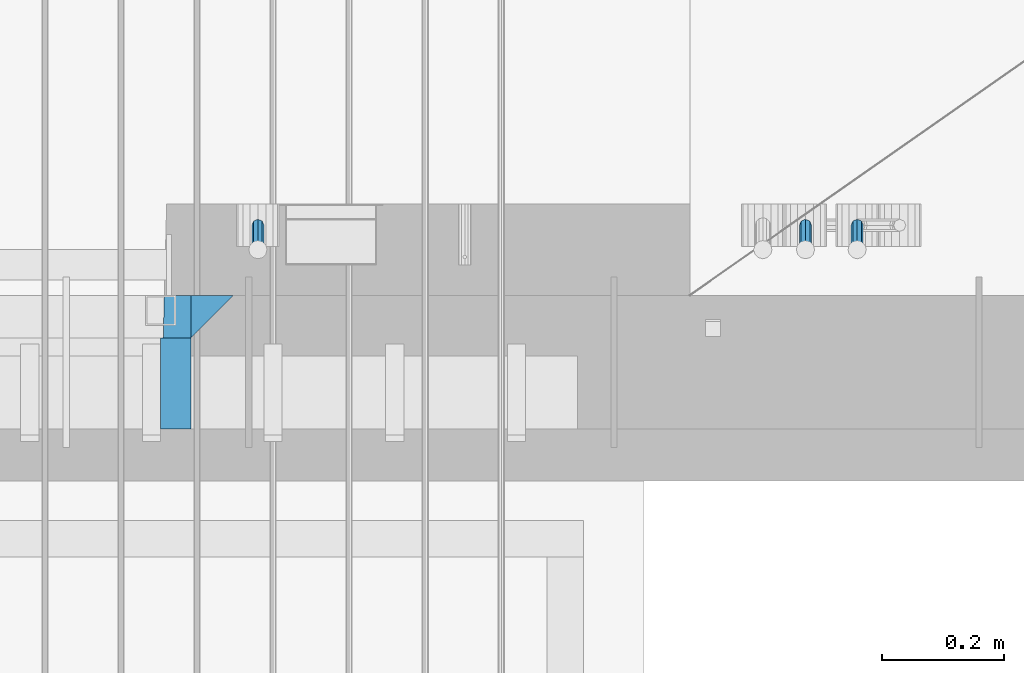
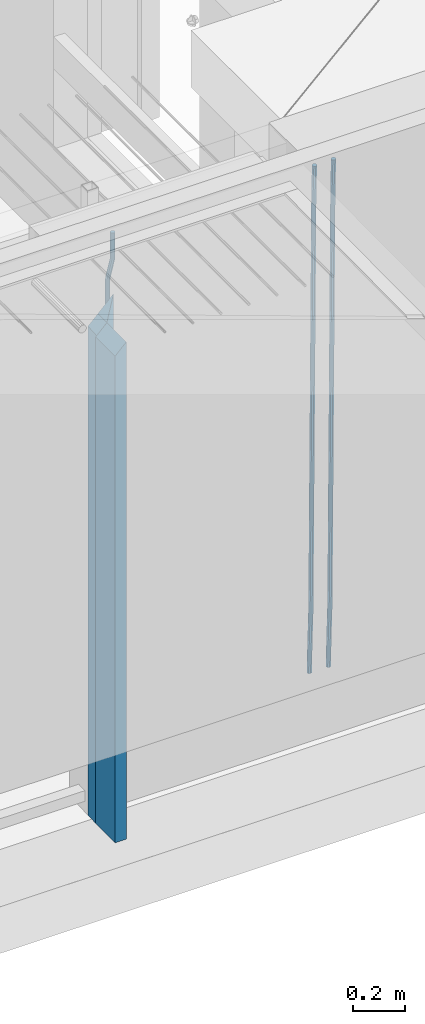
# One storey, part 112 of 325: 6 beams, 1 element without a shape of its own.
"""IFC2X3 building model written with IfcOpenShell, lengths in millimetres."""

from ifc_helpers import new_model, si_unit, frame, origin_with_axes, place, context, subcontext, project, spatial, faceted_brep, material, type_object, element, aggregate, save


model = new_model("IFC2X3")

# Units and contexts
model_context = context("Model", 3, precision=1e-05, world=origin_with_axes())
body_context = subcontext(model_context, "Body", "Model", "MODEL_VIEW")
ifc_project = project(units=[si_unit("LENGTHUNIT", "METRE", prefix="MILLI"), si_unit("AREAUNIT", "SQUARE_METRE"), si_unit("VOLUMEUNIT", "CUBIC_METRE"), si_unit("MASSUNIT", "GRAM", prefix="KILO"), si_unit("TIMEUNIT", "SECOND"), si_unit("PLANEANGLEUNIT", "RADIAN"), si_unit("SOLIDANGLEUNIT", "STERADIAN"), si_unit("THERMODYNAMICTEMPERATUREUNIT", "DEGREE_CELSIUS"), si_unit("LUMINOUSINTENSITYUNIT", "LUMEN")], contexts=[model_context])

# Site, building, storey
site_placement = place(None, origin_with_axes())
site = spatial("IfcSite", under=ifc_project, at=site_placement, CompositionType="ELEMENT")
building_placement = place(site_placement, origin_with_axes())
building = spatial("IfcBuilding", under=site, at=building_placement, CompositionType="ELEMENT")
storey_placement = place(building_placement, origin_with_axes())
storey = spatial("IfcBuildingStorey", under=building, at=storey_placement, Name="1", CompositionType="ELEMENT", Elevation=0.0)

# Assembly, beams
assembly_placement = place(storey_placement, origin_with_axes())
assembly = element("IfcElementAssembly", 1, at=assembly_placement, inside=storey, AssemblyPlace="NOTDEFINED", PredefinedType="REINFORCEMENT_UNIT")
ifc_material_1 = material(Name="CONCRETE/C35/45")
beam_type_1 = type_object("IfcBeamType", PredefinedType="NOTDEFINED")
beam_1_placement = place(assembly_placement, frame((33199.9988923323, 7815.0, 84175.0), z_axis=(-1.0, 3.00000001838171e-08, 0.0), x_axis=(0.0, 0.0, -1.0)))
beam_1 = element("IfcBeam", 2, at=beam_1_placement, type_object=beam_type_1, material=ifc_material_1, Name="SK", context=body_context, shape_type="Brep", body=[
    faceted_brep([(2420.0, -35.0, 35.0), (2420.0, -35.0, -35.0), (2420.0, 35.0, 35.0), (0.0, -35.0, -35.0), (70.0000000000164, 35.0, 35.0), (70.0000000000164, -35.0, 35.0)], [[[0, 1, 2]], [[2, 1, 3, 4]], [[0, 2, 4, 5]], [[1, 0, 5, 3]], [[5, 4, 3]]]),
])
beam_type_2 = type_object("IfcBeamType", PredefinedType="NOTDEFINED")
beam_2_placement = place(assembly_placement, frame((33139.9988923323, 7815.0, 84105.0), z_axis=(-1.0, 3.00000001838171e-08, 0.0), x_axis=(0.0, 0.0, -1.0)))
beam_2 = element("IfcBeam", 3, at=beam_2_placement, type_object=beam_type_2, material=ifc_material_1, Name="SK", context=body_context, shape_type="Brep", body=[
    faceted_brep([(2350.0, -35.0, -25.0), (2350.0, 35.0, -25.0), (2350.0, 35.0, 20.6410256410309), (2350.0, -35.0, 18.8461538461561), (0.0, -35.0, -25.0), (0.0, 35.0, -25.0), (45.6410256410309, 35.0, 20.6410256410254), (43.8461538461561, -35.0, 18.8461538461543)], [[[0, 1, 2, 3]], [[1, 0, 4, 5]], [[2, 1, 5, 6]], [[3, 2, 6, 7]], [[0, 3, 7, 4]], [[6, 5, 4, 7]]]),
])
ifc_material_2 = material(Name="TIMBER")
beam_type_3 = type_object("IfcBeamType", Name="50X150", PredefinedType="NOTDEFINED")
beam_3_placement = place(assembly_placement, frame((33139.9988923323, 7705.0, 84105.0), z_axis=(-1.0, 3.00000001838171e-08, 0.0), x_axis=(0.0, 0.0, -1.0)))
beam_3 = element("IfcBeam", 4, at=beam_3_placement, type_object=beam_type_3, material=ifc_material_2, ObjectType="50X150", context=body_context, shape_type="Brep", body=[
    faceted_brep([(2345.0, -75.0, 25.0), (2345.0, -75.0, -25.0), (2345.0, 75.0, -25.0), (2345.0, 75.0, 25.0), (0.0, -75.0, -25.0), (0.0, 75.0, -25.0), (50.0000000000036, 75.0, 25.0), (50.0000000000036, -75.0, 25.0)], [[[0, 1, 2, 3]], [[4, 5, 2, 1]], [[3, 2, 5, 6]], [[0, 3, 6, 7]], [[1, 0, 7, 4]], [[7, 6, 5, 4]]]),
])
ifc_material_3 = material()
beam_type_4 = type_object("IfcBeamType", Name="D20", PredefinedType="NOTDEFINED")
beam_4_placement = place(assembly_placement, frame((33274.9999999916, 7925.0, 84407.5), z_axis=(0.000415599999849905, 0.999999913638203, 4.76000000899737e-07), x_axis=(0.0, 0.0, -1.0)))
beam_4 = element("IfcBeam", 5, at=beam_4_placement, type_object=beam_type_4, material=ifc_material_3, Name="JM20", ObjectType="D20", context=body_context, shape_type="Brep", body=[
    faceted_brep([(0.0, -10.0, 0.0), (-4.19531716033816e-08, -7.07106781186667, -7.07106781187031), (113.248091332178, -7.0710684840451, -7.0710678117357), (113.248091314759, -10.0000006713562, -2.51020537689328e-10), (0.0, 0.0, -10.0), (113.248091374131, -6.72178430249915e-07, -9.99999999986903), (4.196772351861e-08, 7.07106781186303, -7.07106781186667), (113.248091416113, 7.07106713968824, -7.07106781173934), (0.0, 10.0, 0.0), (113.248091433488, 9.99999932782521, 1.30967237055302e-10), (4.196772351861e-08, 7.07106781185939, 7.07106781185939), (113.248091416113, 7.0710671396846, 7.071067811994), (0.0, 0.0, 10.0), (113.248091374131, -6.72174792271107e-07, 10.0000000001273), (-4.19531716033816e-08, -7.07106781187031, 7.07106781185939), (113.248091332178, -7.0710684840451, 7.071067811994), (130.699843527167, -7.06993249763036, -4.33745683788584), (128.538066582521, -9.99900540317321, 2.39499413731755), (131.594536475241, 0.00119355250353692, -7.12624594330919), (130.698046432328, 7.07220300913468, -4.33773834422391), (128.535525107087, 10.0009944322555, 2.39459602660281), (126.373748162892, 7.07192152754578, 9.1270470011732), (125.479055214906, 0.000795477419160306, 11.9158361066184), (126.37554525779, -7.07021397921199, 9.12732850753673), (240.336258550378, -7.05529970173666, 30.8729495437874), (238.174481606227, -9.98437260450009, 37.6054005176375), (241.230951498423, 0.0158263482953771, 28.0841604381058), (240.334461455612, 7.0868358050102, 30.8726680369582), (238.171940130502, 10.0156272283348, 37.6050024077231), (236.010163186409, 7.08655432384694, 44.3374533824244), (235.115470238379, 0.0154282738185429, 47.1262424881097), (236.011960281176, -7.05558118289991, 44.3377348892536), (253.461915329972, -7.05444528127919, 32.9289287376414), (253.46191532613, -9.98337746617108, 39.9999965521893), (253.461915339081, 0.0166225284556276, 29.9999965443676), (253.461915348205, 7.08769034247234, 32.9289287273205), (253.461915352003, 10.0166225357716, 39.9999965370152), (253.461915348293, 7.08769035281148, 47.0710643509774), (253.461915339183, 0.0166225430875784, 49.999996544273), (253.46191533003, -7.05444527093641, 47.0710643613093), (2417.50000002384, -7.0544364694706, 32.9289287374122), (2417.5000000337, -9.98336865393321, 39.9999965507959), (2417.49999999997, 0.0166313408753922, 29.9999965456082), (2417.49999997609, 7.08769915426274, 32.9289287300708), (2417.4999999662, 10.0166313460668, 39.9999965404204), (2417.49999997608, 7.08769916160054, 47.0710643538114), (2417.49999999994, 0.0166313512581837, 49.9999965456154), (2417.50000002382, -7.05443646212916, 47.0710643611455)], [[[0, 1, 2, 3]], [[1, 4, 5, 2]], [[4, 6, 7, 5]], [[6, 8, 9, 7]], [[8, 10, 11, 9]], [[10, 12, 13, 11]], [[12, 14, 15, 13]], [[14, 0, 3, 15]], [[14, 12, 10, 8, 6, 4, 1, 0]], [[3, 2, 16, 17]], [[2, 5, 18, 16]], [[5, 7, 19, 18]], [[7, 9, 20, 19]], [[9, 11, 21, 20]], [[11, 13, 22, 21]], [[13, 15, 23, 22]], [[15, 3, 17, 23]], [[17, 16, 24, 25]], [[16, 18, 26, 24]], [[18, 19, 27, 26]], [[19, 20, 28, 27]], [[20, 21, 29, 28]], [[21, 22, 30, 29]], [[22, 23, 31, 30]], [[23, 17, 25, 31]], [[25, 24, 32, 33]], [[24, 26, 34, 32]], [[26, 27, 35, 34]], [[27, 28, 36, 35]], [[28, 29, 37, 36]], [[29, 30, 38, 37]], [[30, 31, 39, 38]], [[31, 25, 33, 39]], [[33, 32, 40, 41]], [[32, 34, 42, 40]], [[34, 35, 43, 42]], [[35, 36, 44, 43]], [[36, 37, 45, 44]], [[37, 38, 46, 45]], [[38, 39, 47, 46]], [[39, 33, 41, 47]], [[42, 43, 44, 45, 46, 47, 41, 40]]]),
])
beam_5_placement = place(assembly_placement, frame((34259.9999999961, 7965.00000227913, 81990.0), z_axis=(0.00020576299992186, -0.999642804629538, -0.0267249099901004), x_axis=(-4.30000201928125e-08, -0.0267249099948059, 0.999642825806181)))
beam_5 = element("IfcBeam", 6, at=beam_5_placement, type_object=beam_type_4, material=ifc_material_3, Name="JM20", ObjectType="D20", context=body_context, shape_type="Brep", body=[
    faceted_brep([(0.0, -10.0, 0.0), (-4.19531716033816e-08, -7.07106781186667, -7.07106781187031), (60.4266690400545, -7.0710677960451, -7.07106780570757), (60.4266690441291, -9.99999998418934, 6.15546014159918e-09), (0.0, 0.0, -10.0), (60.426669036824, 1.58106558956206e-08, -9.99999999384454), (4.196772351861e-08, 7.07106781186303, -7.07106781186667), (60.4266690363438, 7.07106782768096, -7.07106780570757), (0.0, 10.0, 0.0), (60.4266690388904, 10.0000000158179, 6.15182216279209e-09), (4.196772351861e-08, 7.07106781185939, 7.07106781185939), (60.4266690429649, 7.07106782768096, 7.07106781802577), (0.0, 0.0, 10.0), (60.4266690461809, 1.58179318532348e-08, 10.0000000061555), (-4.19531716033816e-08, -7.07106781187031, 7.07106781185939), (60.4266690466611, -7.07106779605238, 7.07106781802213), (61.0378400410118, -7.07106779588503, -7.07106780564936), (60.991799419251, -9.99999998403655, 6.21366780251265e-09), (61.0569027789461, 1.5985278878361e-08, -9.99999999378269), (61.0378209396877, 7.07106782784831, -7.07106780564936), (60.9917724058905, 10.0000000159635, 6.21366780251265e-09), (60.9457317841297, 7.07106782781193, 7.0710678180767), (60.9266690461809, 1.59488990902901e-08, 10.0000000062028), (60.9457508854539, -7.07106779591413, 7.0710678180767), (61.6489592143771, -7.07106614513759, -7.06310863441468), (61.5568818710308, -9.9999984576425, 0.00735959856683621), (61.6870830769039, 1.71821739058942e-06, -9.99179257185824), (61.6489210170112, 7.07106947854481, -7.06310888312146), (61.556827851804, 10.0000015422847, 0.00735924683976918), (61.4647505084577, 7.07106922979438, 7.07782747982128), (61.4266266459163, 1.36643211590126e-06, 10.0065114172685), (61.464788705809, -7.07106639389531, 7.07782772852806), (176.543135720174, -7.07075579406956, -5.56673531796696), (176.451058376813, -9.99968810657447, 1.50373291501455), (176.581259582701, 0.000312069292704109, -8.49541925541052), (176.543097522794, 7.07137982961285, -5.56673556667374), (176.451004357587, 10.00031189336, 1.50373256329476), (176.35892701424, 7.07137958085514, 8.57420079627263), (176.320803151699, 0.000311717507429421, 11.5028847337162), (176.358965211621, -7.07075604281999, 8.57420104497578), (177.098753836006, -7.07075429323595, -5.55949898843028), (176.98362511232, -9.99968666800123, 1.510669025065), (177.146421932586, 0.000313595905026887, -8.48805862247536), (177.098706077581, 7.07138133041735, -5.55949936166144), (176.983557571715, 10.0003133318824, 1.51066849724157), (176.868428848029, 7.07138095712435, 8.58083651073321), (176.820760751449, 0.000313067976094317, 11.5093961447819), (176.868476606425, -7.07075466652896, 8.58083688396073), (177.654312950661, -7.07075204110879, -5.54863964998367), (177.516135294456, -9.99968450931192, 1.52107783331303), (177.711524267797, 0.000315886711177882, -8.47701274570863), (177.654255632195, 7.07138358250813, -5.54864021007961), (177.516054233929, 10.0003154905207, 1.5210770412159), (177.377876577739, 7.0713830223176, 8.59079452451624), (177.320665260588, 0.000315094497636892, 11.5191676202448), (177.377933896176, -7.07075260129932, 8.59079508461218), (299.436796249574, -7.07025836271714, -3.1681962331204), (299.298618593355, -9.99919083092027, 3.90152125031091), (299.494007566798, 0.000809565110102994, -6.09656932889993), (299.436738931283, 7.07187726089978, -3.16819679320906), (299.298537533061, 10.0008091689197, 3.90152045822106), (299.160359876842, 7.07187670072017, 10.9712379416487), (299.103148559603, 0.000808772889286047, 13.8996110374392), (299.160417195119, -7.07025892290039, 10.9712385017483), (299.98743051647, -7.07025613056248, -3.15743315966392), (299.971788958996, -9.99918809853989, 3.91467979818117), (299.993912075952, 0.000811591617093654, -6.08679785393178), (299.987423933868, 7.07187949325817, -3.1574327280432), (299.971753863239, 10.0008119014747, 3.91467990454839), (299.95611230444, 7.07187992653053, 10.9867922621015), (299.949630744944, 0.000812204350950196, 13.9161569563694), (299.956118887014, -7.07025569729012, 10.9867918304735), (300.538107039494, -7.07025785017686, -3.16575821840888), (300.644985195438, -9.99919020432935, 3.90450175465594), (300.493854948218, 0.000810030429420294, -6.09435592770024), (300.538151196495, 7.071877773491, -3.16575855385963), (300.645047642858, 10.0008097955724, 3.90450128024895), (300.751925798773, 7.07187744142357, 10.9747612533101), (300.796177890064, 0.000809560813650023, 13.9033589625978), (300.751881641787, -7.07025818224065, 10.9747615887682), (2293.36490490142, -7.07648090940347, -33.2930642912361), (2293.47178305736, -10.0054132635523, -26.2228043181785), (2293.32065281013, -0.00541302880083094, -36.2216620005347), (2293.36494905842, 7.06565471425711, -33.2930646266868), (2293.47184550477, 9.99458673634581, -26.2228047925819), (2293.57872366071, 7.06565438219332, -19.1525448195243), (2293.62297575199, -0.00541349841296324, -16.2239471102366), (2293.57867950371, -7.0764812414709, -19.1525444840736), (2294.0658245362, -7.07648309818615, -33.3036607065333), (2294.05312277409, -10.0054150789219, -26.2315929392535), (2294.10928714235, -0.00541549149056664, -36.2335844756526), (2294.15805078732, 7.06565223761572, -33.3050546393533), (2294.18355038921, 9.99458451388637, -26.2335642579346), (2294.17084862708, 7.06565253314329, -19.1614964906439), (2294.12738602093, -0.00541507354500936, -16.2315727215355), (2294.07862237596, -7.07648280265857, -19.1601025578348), (2294.76670261032, -7.08562269121467, -33.294332712383), (2294.63442802057, -10.0129954178956, -26.2238563411993), (2294.89787471293, -0.0156988342423574, -36.2230891548279), (2294.95110548967, 7.05531064255774, -33.2944998654275), (2294.89521307347, 9.98530428734011, -26.2240927312887), (2294.76293848372, 7.0579315606592, -19.1536163601049), (2294.63176638114, -0.0119922963167483, -16.2248599176673), (2294.57853560438, -7.08300177311321, -19.1534492070678), (2316.52657204497, -7.36937582653991, -33.0047303660212), (2316.39429745522, -10.2967485532172, -25.9342539948302), (2316.65774414754, -0.299451969567599, -35.9334868084661), (2316.7109749243, 6.7715575072325, -33.0048975190657), (2316.65508250811, 9.70155115201487, -25.9344903849269), (2316.52280791836, 6.7741784253376, -18.8640140137468), (2316.39163581574, -0.295745431634714, -15.9352575713092), (2316.33840503903, -7.36675490843481, -18.863846860706), (2317.16202064224, -7.37766220584308, -32.9962731735213), (2317.05438744847, -10.3053562613532, -25.9254688497131), (2317.23607125619, -0.306993473008333, -35.925789846493), (2317.23316144495, 6.76474808850253, -32.9979477328052), (2317.15499573652, 9.6950321815566, -25.9278370341635), (2317.04736254275, 6.7673381260538, -18.8570327103698), (2316.97331192881, -0.303330606784584, -15.9275160373909), (2316.97622174003, -7.37507216829545, -18.8553581510787), (2317.79752306276, -7.37578610372293, -32.9880110666527), (2317.71453320107, -10.3033876998124, -25.9168792378296), (2317.81444760226, -0.305295583297266, -35.918287695793), (2317.75539265381, 6.76628640723357, -32.9911928173897), (2317.65495180529, 9.69652304524061, -25.9213789128698), (2317.5719619436, 6.76892144914746, -18.8502470840467), (2317.55503740412, -0.301569071270933, -15.9199704549137), (2317.61409235255, -7.3731510618054, -18.847065333317), (2417.8183084176, -7.07752398473531, -31.6906369377139), (2417.73531855589, -10.0051255808248, -24.6195051088798), (2417.83523295709, -0.007033464313281, -34.6209135668432), (2417.77617800863, 7.06454852621755, -31.6938186884508), (2417.67573716014, 9.99478516423187, -24.6240047839383), (2417.59274729842, 7.06718356813872, -17.5528729551006), (2417.57582275895, -0.00330695228694822, -14.6225963259749), (2417.6348777074, -7.07488894281778, -17.5496912043673)], [[[0, 1, 2, 3]], [[1, 4, 5, 2]], [[4, 6, 7, 5]], [[6, 8, 9, 7]], [[8, 10, 11, 9]], [[10, 12, 13, 11]], [[12, 14, 15, 13]], [[14, 0, 3, 15]], [[14, 12, 10, 8, 6, 4, 1, 0]], [[3, 2, 16, 17]], [[2, 5, 18, 16]], [[5, 7, 19, 18]], [[7, 9, 20, 19]], [[9, 11, 21, 20]], [[11, 13, 22, 21]], [[13, 15, 23, 22]], [[15, 3, 17, 23]], [[17, 16, 24, 25]], [[16, 18, 26, 24]], [[18, 19, 27, 26]], [[19, 20, 28, 27]], [[20, 21, 29, 28]], [[21, 22, 30, 29]], [[22, 23, 31, 30]], [[23, 17, 25, 31]], [[25, 24, 32, 33]], [[24, 26, 34, 32]], [[26, 27, 35, 34]], [[27, 28, 36, 35]], [[28, 29, 37, 36]], [[29, 30, 38, 37]], [[30, 31, 39, 38]], [[31, 25, 33, 39]], [[33, 32, 40, 41]], [[32, 34, 42, 40]], [[34, 35, 43, 42]], [[35, 36, 44, 43]], [[36, 37, 45, 44]], [[37, 38, 46, 45]], [[38, 39, 47, 46]], [[39, 33, 41, 47]], [[41, 40, 48, 49]], [[40, 42, 50, 48]], [[42, 43, 51, 50]], [[43, 44, 52, 51]], [[44, 45, 53, 52]], [[45, 46, 54, 53]], [[46, 47, 55, 54]], [[47, 41, 49, 55]], [[49, 48, 56, 57]], [[48, 50, 58, 56]], [[50, 51, 59, 58]], [[51, 52, 60, 59]], [[52, 53, 61, 60]], [[53, 54, 62, 61]], [[54, 55, 63, 62]], [[55, 49, 57, 63]], [[57, 56, 64, 65]], [[56, 58, 66, 64]], [[58, 59, 67, 66]], [[59, 60, 68, 67]], [[60, 61, 69, 68]], [[61, 62, 70, 69]], [[62, 63, 71, 70]], [[63, 57, 65, 71]], [[65, 64, 72, 73]], [[64, 66, 74, 72]], [[66, 67, 75, 74]], [[67, 68, 76, 75]], [[68, 69, 77, 76]], [[69, 70, 78, 77]], [[70, 71, 79, 78]], [[71, 65, 73, 79]], [[73, 72, 80, 81]], [[72, 74, 82, 80]], [[74, 75, 83, 82]], [[75, 76, 84, 83]], [[76, 77, 85, 84]], [[77, 78, 86, 85]], [[78, 79, 87, 86]], [[79, 73, 81, 87]], [[81, 80, 88, 89]], [[80, 82, 90, 88]], [[82, 83, 91, 90]], [[83, 84, 92, 91]], [[84, 85, 93, 92]], [[85, 86, 94, 93]], [[86, 87, 95, 94]], [[87, 81, 89, 95]], [[89, 88, 96, 97]], [[88, 90, 98, 96]], [[90, 91, 99, 98]], [[91, 92, 100, 99]], [[92, 93, 101, 100]], [[93, 94, 102, 101]], [[94, 95, 103, 102]], [[95, 89, 97, 103]], [[97, 96, 104, 105]], [[96, 98, 106, 104]], [[98, 99, 107, 106]], [[99, 100, 108, 107]], [[100, 101, 109, 108]], [[101, 102, 110, 109]], [[102, 103, 111, 110]], [[103, 97, 105, 111]], [[105, 104, 112, 113]], [[104, 106, 114, 112]], [[106, 107, 115, 114]], [[107, 108, 116, 115]], [[108, 109, 117, 116]], [[109, 110, 118, 117]], [[110, 111, 119, 118]], [[111, 105, 113, 119]], [[113, 112, 120, 121]], [[112, 114, 122, 120]], [[114, 115, 123, 122]], [[115, 116, 124, 123]], [[116, 117, 125, 124]], [[117, 118, 126, 125]], [[118, 119, 127, 126]], [[119, 113, 121, 127]], [[121, 120, 128, 129]], [[120, 122, 130, 128]], [[122, 123, 131, 130]], [[123, 124, 132, 131]], [[124, 125, 133, 132]], [[125, 126, 134, 133]], [[126, 127, 135, 134]], [[127, 121, 129, 135]], [[130, 131, 132, 133, 134, 135, 129, 128]]]),
])
beam_6_placement = place(assembly_placement, frame((34174.9999999961, 7965.00000227913, 81990.0), z_axis=(0.00020576299992186, -0.999642804629538, -0.0267249099901004), x_axis=(-4.30000201928125e-08, -0.0267249099948059, 0.999642825806181)))
beam_6 = element("IfcBeam", 7, at=beam_6_placement, type_object=beam_type_4, material=ifc_material_3, Name="JM20", ObjectType="D20", context=body_context, shape_type="Brep", body=[
    faceted_brep([(0.0, -10.0, 0.0), (-4.19531716033816e-08, -7.07106781186667, -7.07106781187031), (60.4266690400545, -7.0710677960451, -7.07106780570757), (60.4266690441291, -9.99999998418934, 6.15546014159918e-09), (0.0, 0.0, -10.0), (60.426669036824, 1.58106558956206e-08, -9.99999999384454), (4.196772351861e-08, 7.07106781186303, -7.07106781186667), (60.4266690363438, 7.07106782768096, -7.07106780570757), (0.0, 10.0, 0.0), (60.4266690388904, 10.0000000158179, 6.15182216279209e-09), (4.196772351861e-08, 7.07106781185939, 7.07106781185939), (60.4266690429649, 7.07106782768096, 7.07106781802577), (0.0, 0.0, 10.0), (60.4266690461809, 1.58179318532348e-08, 10.0000000061555), (-4.19531716033816e-08, -7.07106781187031, 7.07106781185939), (60.4266690466611, -7.07106779605238, 7.07106781802213), (61.0378400410118, -7.07106779588503, -7.07106780564936), (60.991799419251, -9.99999998403655, 6.21366780251265e-09), (61.0569027789461, 1.5985278878361e-08, -9.99999999378269), (61.0378209396877, 7.07106782784831, -7.07106780564936), (60.9917724058905, 10.0000000159635, 6.21366780251265e-09), (60.9457317841297, 7.07106782781193, 7.0710678180767), (60.9266690461809, 1.59488990902901e-08, 10.0000000062028), (60.9457508854539, -7.07106779591413, 7.0710678180767), (61.6489592143771, -7.07106614513759, -7.06310863441468), (61.5568818710308, -9.9999984576425, 0.00735959856683621), (61.6870830769039, 1.71821739058942e-06, -9.99179257185824), (61.6489210170112, 7.07106947854481, -7.06310888312146), (61.556827851804, 10.0000015422847, 0.00735924683976918), (61.4647505084577, 7.07106922979438, 7.07782747982128), (61.4266266459163, 1.36643211590126e-06, 10.0065114172685), (61.464788705809, -7.07106639389531, 7.07782772852806), (176.543135720174, -7.07075579406956, -5.56673531796696), (176.451058376813, -9.99968810657447, 1.50373291501455), (176.581259582701, 0.000312069292704109, -8.49541925541052), (176.543097522794, 7.07137982961285, -5.56673556667374), (176.451004357587, 10.00031189336, 1.50373256329476), (176.35892701424, 7.07137958085514, 8.57420079627263), (176.320803151699, 0.000311717507429421, 11.5028847337162), (176.358965211621, -7.07075604281999, 8.57420104497578), (177.098753836006, -7.07075429323595, -5.55949898843028), (176.98362511232, -9.99968666800123, 1.510669025065), (177.146421932586, 0.000313595905026887, -8.48805862247536), (177.098706077581, 7.07138133041735, -5.55949936166144), (176.983557571715, 10.0003133318824, 1.51066849724157), (176.868428848029, 7.07138095712435, 8.58083651073321), (176.820760751449, 0.000313067976094317, 11.5093961447819), (176.868476606425, -7.07075466652896, 8.58083688396073), (177.654312950661, -7.07075204110879, -5.54863964998367), (177.516135294456, -9.99968450931192, 1.52107783331303), (177.711524267797, 0.000315886711177882, -8.47701274570863), (177.654255632195, 7.07138358250813, -5.54864021007961), (177.516054233929, 10.0003154905207, 1.5210770412159), (177.377876577739, 7.0713830223176, 8.59079452451624), (177.320665260588, 0.000315094497636892, 11.5191676202448), (177.377933896176, -7.07075260129932, 8.59079508461218), (299.436796249574, -7.07025836271714, -3.1681962331204), (299.298618593355, -9.99919083092027, 3.90152125031091), (299.494007566798, 0.000809565110102994, -6.09656932889993), (299.436738931283, 7.07187726089978, -3.16819679320906), (299.298537533061, 10.0008091689197, 3.90152045822106), (299.160359876842, 7.07187670072017, 10.9712379416487), (299.103148559603, 0.000808772889286047, 13.8996110374392), (299.160417195119, -7.07025892290039, 10.9712385017483), (299.98743051647, -7.07025613056248, -3.15743315966392), (299.971788958996, -9.99918809853989, 3.91467979818117), (299.993912075952, 0.000811591617093654, -6.08679785393178), (299.987423933868, 7.07187949325817, -3.1574327280432), (299.971753863239, 10.0008119014747, 3.91467990454839), (299.95611230444, 7.07187992653053, 10.9867922621015), (299.949630744944, 0.000812204350950196, 13.9161569563694), (299.956118887014, -7.07025569729012, 10.9867918304735), (300.538107039494, -7.07025785017686, -3.16575821840888), (300.644985195438, -9.99919020432935, 3.90450175465594), (300.493854948218, 0.000810030429420294, -6.09435592770024), (300.538151196495, 7.071877773491, -3.16575855385963), (300.645047642858, 10.0008097955724, 3.90450128024895), (300.751925798773, 7.07187744142357, 10.9747612533101), (300.796177890064, 0.000809560813650023, 13.9033589625978), (300.751881641787, -7.07025818224065, 10.9747615887682), (2293.36490490142, -7.07648090940347, -33.2930642912361), (2293.47178305736, -10.0054132635523, -26.2228043181785), (2293.32065281013, -0.00541302880083094, -36.2216620005347), (2293.36494905842, 7.06565471425711, -33.2930646266868), (2293.47184550477, 9.99458673634581, -26.2228047925819), (2293.57872366071, 7.06565438219332, -19.1525448195243), (2293.62297575199, -0.00541349841296324, -16.2239471102366), (2293.57867950371, -7.0764812414709, -19.1525444840736), (2294.0658245362, -7.07648309818615, -33.3036607065333), (2294.05312277409, -10.0054150789219, -26.2315929392535), (2294.10928714235, -0.00541549149056664, -36.2335844756526), (2294.15805078732, 7.06565223761572, -33.3050546393533), (2294.18355038921, 9.99458451388637, -26.2335642579346), (2294.17084862708, 7.06565253314329, -19.1614964906439), (2294.12738602093, -0.00541507354500936, -16.2315727215355), (2294.07862237596, -7.07648280265857, -19.1601025578348), (2294.76670261032, -7.08562269121467, -33.294332712383), (2294.63442802057, -10.0129954178956, -26.2238563411993), (2294.89787471293, -0.0156988342423574, -36.2230891548279), (2294.95110548967, 7.05531064255774, -33.2944998654275), (2294.89521307347, 9.98530428734011, -26.2240927312887), (2294.76293848372, 7.0579315606592, -19.1536163601049), (2294.63176638114, -0.0119922963167483, -16.2248599176673), (2294.57853560438, -7.08300177311321, -19.1534492070678), (2316.52657204497, -7.36937582653991, -33.0047303660212), (2316.39429745522, -10.2967485532172, -25.9342539948302), (2316.65774414754, -0.299451969567599, -35.9334868084661), (2316.7109749243, 6.7715575072325, -33.0048975190657), (2316.65508250811, 9.70155115201487, -25.9344903849269), (2316.52280791836, 6.7741784253376, -18.8640140137468), (2316.39163581574, -0.295745431634714, -15.9352575713092), (2316.33840503903, -7.36675490843481, -18.863846860706), (2317.16202064224, -7.37766220584308, -32.9962731735213), (2317.05438744847, -10.3053562613532, -25.9254688497131), (2317.23607125619, -0.306993473008333, -35.925789846493), (2317.23316144495, 6.76474808850253, -32.9979477328052), (2317.15499573652, 9.6950321815566, -25.9278370341635), (2317.04736254275, 6.7673381260538, -18.8570327103698), (2316.97331192881, -0.303330606784584, -15.9275160373909), (2316.97622174003, -7.37507216829545, -18.8553581510787), (2317.79752306276, -7.37578610372293, -32.9880110666527), (2317.71453320107, -10.3033876998124, -25.9168792378296), (2317.81444760226, -0.305295583297266, -35.918287695793), (2317.75539265381, 6.76628640723357, -32.9911928173897), (2317.65495180529, 9.69652304524061, -25.9213789128698), (2317.5719619436, 6.76892144914746, -18.8502470840467), (2317.55503740412, -0.301569071270933, -15.9199704549137), (2317.61409235255, -7.3731510618054, -18.847065333317), (2417.8183084176, -7.07752398473531, -31.6906369377139), (2417.73531855589, -10.0051255808248, -24.6195051088798), (2417.83523295709, -0.007033464313281, -34.6209135668432), (2417.77617800863, 7.06454852621755, -31.6938186884508), (2417.67573716014, 9.99478516423187, -24.6240047839383), (2417.59274729842, 7.06718356813872, -17.5528729551006), (2417.57582275895, -0.00330695228694822, -14.6225963259749), (2417.6348777074, -7.07488894281778, -17.5496912043673)], [[[0, 1, 2, 3]], [[1, 4, 5, 2]], [[4, 6, 7, 5]], [[6, 8, 9, 7]], [[8, 10, 11, 9]], [[10, 12, 13, 11]], [[12, 14, 15, 13]], [[14, 0, 3, 15]], [[14, 12, 10, 8, 6, 4, 1, 0]], [[3, 2, 16, 17]], [[2, 5, 18, 16]], [[5, 7, 19, 18]], [[7, 9, 20, 19]], [[9, 11, 21, 20]], [[11, 13, 22, 21]], [[13, 15, 23, 22]], [[15, 3, 17, 23]], [[17, 16, 24, 25]], [[16, 18, 26, 24]], [[18, 19, 27, 26]], [[19, 20, 28, 27]], [[20, 21, 29, 28]], [[21, 22, 30, 29]], [[22, 23, 31, 30]], [[23, 17, 25, 31]], [[25, 24, 32, 33]], [[24, 26, 34, 32]], [[26, 27, 35, 34]], [[27, 28, 36, 35]], [[28, 29, 37, 36]], [[29, 30, 38, 37]], [[30, 31, 39, 38]], [[31, 25, 33, 39]], [[33, 32, 40, 41]], [[32, 34, 42, 40]], [[34, 35, 43, 42]], [[35, 36, 44, 43]], [[36, 37, 45, 44]], [[37, 38, 46, 45]], [[38, 39, 47, 46]], [[39, 33, 41, 47]], [[41, 40, 48, 49]], [[40, 42, 50, 48]], [[42, 43, 51, 50]], [[43, 44, 52, 51]], [[44, 45, 53, 52]], [[45, 46, 54, 53]], [[46, 47, 55, 54]], [[47, 41, 49, 55]], [[49, 48, 56, 57]], [[48, 50, 58, 56]], [[50, 51, 59, 58]], [[51, 52, 60, 59]], [[52, 53, 61, 60]], [[53, 54, 62, 61]], [[54, 55, 63, 62]], [[55, 49, 57, 63]], [[57, 56, 64, 65]], [[56, 58, 66, 64]], [[58, 59, 67, 66]], [[59, 60, 68, 67]], [[60, 61, 69, 68]], [[61, 62, 70, 69]], [[62, 63, 71, 70]], [[63, 57, 65, 71]], [[65, 64, 72, 73]], [[64, 66, 74, 72]], [[66, 67, 75, 74]], [[67, 68, 76, 75]], [[68, 69, 77, 76]], [[69, 70, 78, 77]], [[70, 71, 79, 78]], [[71, 65, 73, 79]], [[73, 72, 80, 81]], [[72, 74, 82, 80]], [[74, 75, 83, 82]], [[75, 76, 84, 83]], [[76, 77, 85, 84]], [[77, 78, 86, 85]], [[78, 79, 87, 86]], [[79, 73, 81, 87]], [[81, 80, 88, 89]], [[80, 82, 90, 88]], [[82, 83, 91, 90]], [[83, 84, 92, 91]], [[84, 85, 93, 92]], [[85, 86, 94, 93]], [[86, 87, 95, 94]], [[87, 81, 89, 95]], [[89, 88, 96, 97]], [[88, 90, 98, 96]], [[90, 91, 99, 98]], [[91, 92, 100, 99]], [[92, 93, 101, 100]], [[93, 94, 102, 101]], [[94, 95, 103, 102]], [[95, 89, 97, 103]], [[97, 96, 104, 105]], [[96, 98, 106, 104]], [[98, 99, 107, 106]], [[99, 100, 108, 107]], [[100, 101, 109, 108]], [[101, 102, 110, 109]], [[102, 103, 111, 110]], [[103, 97, 105, 111]], [[105, 104, 112, 113]], [[104, 106, 114, 112]], [[106, 107, 115, 114]], [[107, 108, 116, 115]], [[108, 109, 117, 116]], [[109, 110, 118, 117]], [[110, 111, 119, 118]], [[111, 105, 113, 119]], [[113, 112, 120, 121]], [[112, 114, 122, 120]], [[114, 115, 123, 122]], [[115, 116, 124, 123]], [[116, 117, 125, 124]], [[117, 118, 126, 125]], [[118, 119, 127, 126]], [[119, 113, 121, 127]], [[121, 120, 128, 129]], [[120, 122, 130, 128]], [[122, 123, 131, 130]], [[123, 124, 132, 131]], [[124, 125, 133, 132]], [[125, 126, 134, 133]], [[126, 127, 135, 134]], [[127, 121, 129, 135]], [[130, 131, 132, 133, 134, 135, 129, 128]]]),
])
aggregate(assembly, [beam_4, beam_5, beam_6, beam_1, beam_2, beam_3])

save(model, "model.ifc")
